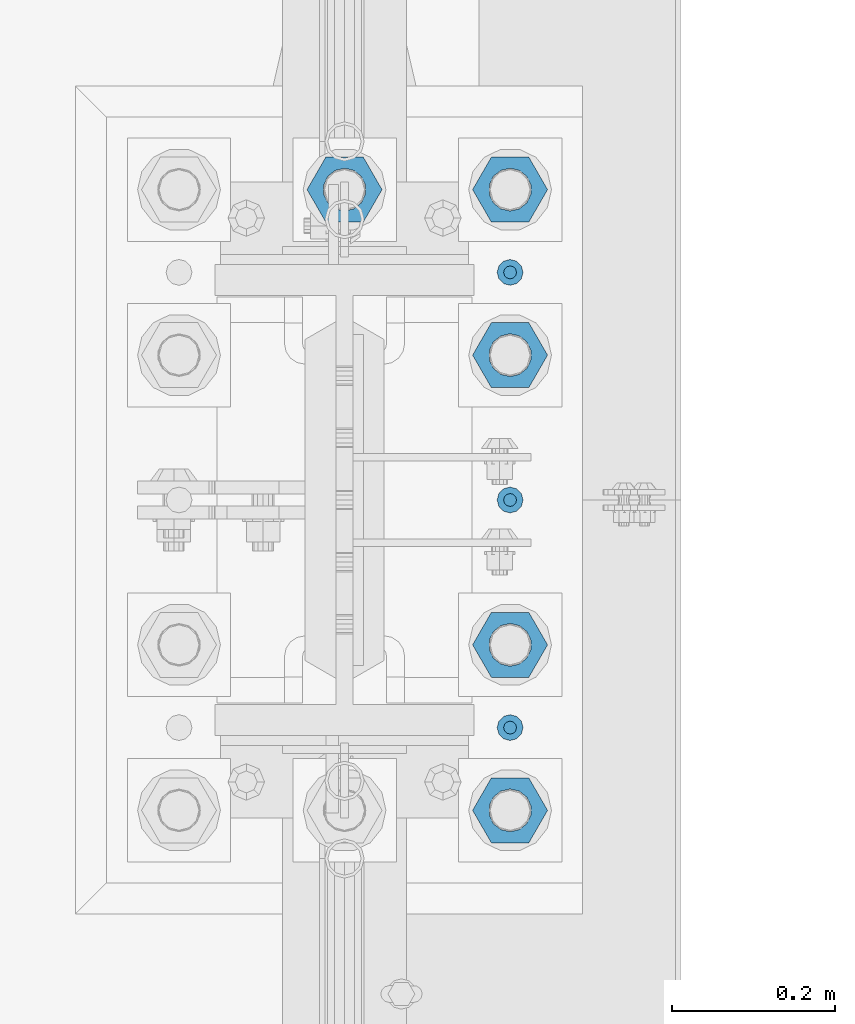
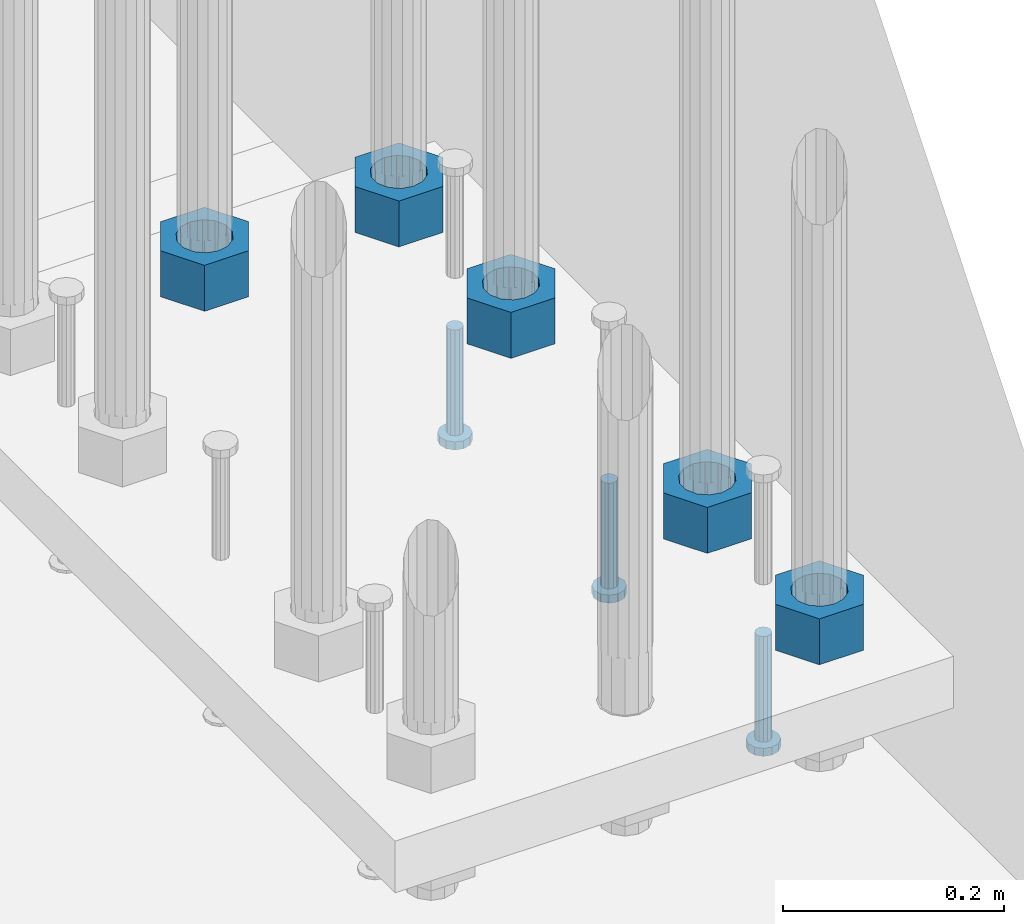
# One storey, part 1273 of 1876: 8 beams, 1 element without a shape of its own.
"""IFC2X3 building model written with IfcOpenShell, lengths in millimetres."""

from ifc_helpers import new_model, si_unit, frame, origin_with_axes, place, context, subcontext, project, spatial, faceted_brep, material, type_object, element, aggregate, save


model = new_model("IFC2X3")

# Units and contexts
model_context = context("Model", 3, precision=1e-05, world=origin_with_axes())
body_context = subcontext(model_context, "Body", "Model", "MODEL_VIEW")
ifc_project = project(units=[si_unit("LENGTHUNIT", "METRE", prefix="MILLI"), si_unit("AREAUNIT", "SQUARE_METRE"), si_unit("VOLUMEUNIT", "CUBIC_METRE"), si_unit("MASSUNIT", "GRAM", prefix="KILO"), si_unit("TIMEUNIT", "SECOND"), si_unit("PLANEANGLEUNIT", "RADIAN"), si_unit("SOLIDANGLEUNIT", "STERADIAN"), si_unit("THERMODYNAMICTEMPERATUREUNIT", "DEGREE_CELSIUS"), si_unit("LUMINOUSINTENSITYUNIT", "LUMEN")], contexts=[model_context])

# Site, building, storey
site_placement = place(None, origin_with_axes())
site = spatial("IfcSite", under=ifc_project, at=site_placement, CompositionType="ELEMENT")
building_placement = place(site_placement, origin_with_axes())
building = spatial("IfcBuilding", under=site, at=building_placement, Name="Undefined", CompositionType="ELEMENT")
storey_placement = place(building_placement, origin_with_axes())
storey = spatial("IfcBuildingStorey", under=building, at=storey_placement, Name="Undefined", CompositionType="ELEMENT", Elevation=0.0)

# Assembly, beams
assembly_placement = place(storey_placement, origin_with_axes())
assembly = element("IfcElementAssembly", 1, at=assembly_placement, inside=storey, Name="TEMPLATE", AssemblyPlace="NOTDEFINED", PredefinedType="RIGID_FRAME")
ifc_material_1 = material(Name="STEEL/A563")
beam_type_1 = type_object("IfcBeamType", Name="2_HEAVY_HEX_NUT", PredefinedType="NOTDEFINED")
beam_1_placement = place(assembly_placement, frame((7823.2, 1142.99999847412, -685.799998474121), z_axis=(0.0, 1.0, 0.0), x_axis=(0.0, 0.0, -1.0)))
beam_1 = element("IfcBeam", 2, at=beam_1_placement, type_object=beam_type_1, material=ifc_material_1, Name="NUT", ObjectType="2_HEAVY_HEX_NUT", context=body_context, shape_type="Brep", body=[
    faceted_brep([(0.0, -46.0369987487793, 9.09494701772928e-13), (0.0, -23.0184993743896, -39.869213104248), (50.8, -23.0184993743896, -39.869213104248), (50.8, -46.0369987487793, 9.09494701772928e-13), (0.0, 23.0184993743896, -39.869213104248), (50.8, 23.0184993743896, -39.869213104248), (0.0, 46.0369987487793, -9.09494701772928e-13), (50.8, 46.0369987487793, -9.09494701772928e-13), (0.0, 23.0184993743896, 39.869213104248), (50.8, 23.0184993743896, 39.869213104248), (0.0, -23.0184993743896, 39.869213104248), (50.8, -23.0184993743896, 39.869213104248), (0.0, 0.0, 26.1940002441406), (0.0, 11.3650617044514, 23.5999013092769), (50.8, 11.3650617044513, 23.5999013092771), (50.8, 0.0, 26.1940002441406), (0.0, 20.4791109456437, 16.3316083006703), (50.8, 20.4791109456439, 16.3316083006703), (0.0, 25.5370200498346, 5.82867859874477), (50.8, 25.5370200498343, 5.82867859874455), (0.0, 25.5370200498346, -5.82867859874477), (50.8, 25.5370200498343, -5.82867859874455), (0.0, 20.4791109456437, -16.3316083006703), (50.8, 20.4791109456439, -16.3316083006703), (0.0, 11.3650617044514, -23.5999013092769), (50.8, 11.3650617044514, -23.5999013092771), (0.0, 0.0, -26.1940002441406), (50.8, 0.0, -26.1940002441406), (0.0, -11.3650617044514, -23.5999013092769), (50.8, -11.3650617044513, -23.5999013092771), (0.0, -20.4791109456437, -16.3316083006703), (50.8, -20.4791109456439, -16.3316083006703), (0.0, -25.5370200498346, -5.82867859874477), (50.8, -25.5370200498343, -5.82867859874455), (0.0, -25.5370200498346, 5.82867859874477), (50.8, -25.5370200498343, 5.82867859874455), (0.0, -20.4791109456437, 16.3316083006703), (50.8, -20.4791109456439, 16.3316083006703), (0.0, -11.3650617044514, 23.5999013092769), (50.8, -11.3650617044514, 23.5999013092771)], [[[0, 1, 2, 3]], [[1, 4, 5, 2]], [[4, 6, 7, 5]], [[6, 8, 9, 7]], [[8, 10, 11, 9]], [[10, 0, 3, 11]], [[12, 13, 14, 15]], [[13, 16, 17, 14]], [[16, 18, 19, 17]], [[18, 20, 21, 19]], [[20, 22, 23, 21]], [[22, 24, 25, 23]], [[24, 26, 27, 25]], [[26, 28, 29, 27]], [[28, 30, 31, 29]], [[30, 32, 33, 31]], [[32, 34, 35, 33]], [[34, 36, 37, 35]], [[36, 38, 39, 37]], [[38, 12, 15, 39]], [[5, 7, 9, 11, 3, 2], [17, 19, 21, 23, 25, 27, 29, 31, 33, 35, 37, 39, 15, 14]], [[10, 8, 6, 4, 1, 0], [38, 36, 34, 32, 30, 28, 26, 24, 22, 20, 18, 16, 13, 12]]]),
])
beam_2_placement = place(assembly_placement, frame((7823.2, 1346.19999847412, -685.799998474121), z_axis=(0.0, 1.0, 0.0), x_axis=(0.0, 0.0, -1.0)))
beam_2 = element("IfcBeam", 3, at=beam_2_placement, type_object=beam_type_1, material=ifc_material_1, Name="NUT", ObjectType="2_HEAVY_HEX_NUT", context=body_context, shape_type="Brep", body=[
    faceted_brep([(0.0, -46.0369987487793, 9.09494701772928e-13), (0.0, -23.0184993743896, -39.869213104248), (50.8, -23.0184993743896, -39.869213104248), (50.8, -46.0369987487793, 9.09494701772928e-13), (0.0, 23.0184993743896, -39.869213104248), (50.8, 23.0184993743896, -39.869213104248), (0.0, 46.0369987487793, -9.09494701772928e-13), (50.8, 46.0369987487793, -9.09494701772928e-13), (0.0, 23.0184993743896, 39.869213104248), (50.8, 23.0184993743896, 39.869213104248), (0.0, -23.0184993743896, 39.869213104248), (50.8, -23.0184993743896, 39.869213104248), (0.0, 0.0, 26.1940002441406), (0.0, 11.3650617044514, 23.5999013092769), (50.8, 11.3650617044513, 23.5999013092771), (50.8, 0.0, 26.1940002441406), (0.0, 20.4791109456437, 16.3316083006703), (50.8, 20.4791109456439, 16.3316083006703), (0.0, 25.5370200498346, 5.82867859874477), (50.8, 25.5370200498343, 5.82867859874455), (0.0, 25.5370200498346, -5.82867859874477), (50.8, 25.5370200498343, -5.82867859874455), (0.0, 20.4791109456437, -16.3316083006703), (50.8, 20.4791109456439, -16.3316083006703), (0.0, 11.3650617044514, -23.5999013092769), (50.8, 11.3650617044514, -23.5999013092771), (0.0, 0.0, -26.1940002441406), (50.8, 0.0, -26.1940002441406), (0.0, -11.3650617044514, -23.5999013092769), (50.8, -11.3650617044513, -23.5999013092771), (0.0, -20.4791109456437, -16.3316083006703), (50.8, -20.4791109456439, -16.3316083006703), (0.0, -25.5370200498346, -5.82867859874477), (50.8, -25.5370200498343, -5.82867859874455), (0.0, -25.5370200498346, 5.82867859874477), (50.8, -25.5370200498343, 5.82867859874455), (0.0, -20.4791109456437, 16.3316083006703), (50.8, -20.4791109456439, 16.3316083006703), (0.0, -11.3650617044514, 23.5999013092769), (50.8, -11.3650617044514, 23.5999013092771)], [[[0, 1, 2, 3]], [[1, 4, 5, 2]], [[4, 6, 7, 5]], [[6, 8, 9, 7]], [[8, 10, 11, 9]], [[10, 0, 3, 11]], [[12, 13, 14, 15]], [[13, 16, 17, 14]], [[16, 18, 19, 17]], [[18, 20, 21, 19]], [[20, 22, 23, 21]], [[22, 24, 25, 23]], [[24, 26, 27, 25]], [[26, 28, 29, 27]], [[28, 30, 31, 29]], [[30, 32, 33, 31]], [[32, 34, 35, 33]], [[34, 36, 37, 35]], [[36, 38, 39, 37]], [[38, 12, 15, 39]], [[5, 7, 9, 11, 3, 2], [17, 19, 21, 23, 25, 27, 29, 31, 33, 35, 37, 39, 15, 14]], [[10, 8, 6, 4, 1, 0], [38, 36, 34, 32, 30, 28, 26, 24, 22, 20, 18, 16, 13, 12]]]),
])
beam_3_placement = place(assembly_placement, frame((7823.2, 1701.79999847412, -685.799998474121), z_axis=(0.0, 1.0, 0.0), x_axis=(0.0, 0.0, -1.0)))
beam_3 = element("IfcBeam", 4, at=beam_3_placement, type_object=beam_type_1, material=ifc_material_1, Name="NUT", ObjectType="2_HEAVY_HEX_NUT", context=body_context, shape_type="Brep", body=[
    faceted_brep([(0.0, -46.0369987487793, 9.09494701772928e-13), (0.0, -23.0184993743896, -39.869213104248), (50.8, -23.0184993743896, -39.869213104248), (50.8, -46.0369987487793, 9.09494701772928e-13), (0.0, 23.0184993743896, -39.869213104248), (50.8, 23.0184993743896, -39.869213104248), (0.0, 46.0369987487793, -9.09494701772928e-13), (50.8, 46.0369987487793, -9.09494701772928e-13), (0.0, 23.0184993743896, 39.869213104248), (50.8, 23.0184993743896, 39.869213104248), (0.0, -23.0184993743896, 39.869213104248), (50.8, -23.0184993743896, 39.869213104248), (0.0, 0.0, 26.1940002441406), (0.0, 11.3650617044514, 23.5999013092769), (50.8, 11.3650617044513, 23.5999013092771), (50.8, 0.0, 26.1940002441406), (0.0, 20.4791109456437, 16.3316083006703), (50.8, 20.4791109456439, 16.3316083006703), (0.0, 25.5370200498346, 5.82867859874477), (50.8, 25.5370200498343, 5.82867859874455), (0.0, 25.5370200498346, -5.82867859874477), (50.8, 25.5370200498343, -5.82867859874455), (0.0, 20.4791109456437, -16.3316083006703), (50.8, 20.4791109456439, -16.3316083006703), (0.0, 11.3650617044514, -23.5999013092769), (50.8, 11.3650617044514, -23.5999013092771), (0.0, 0.0, -26.1940002441406), (50.8, 0.0, -26.1940002441406), (0.0, -11.3650617044514, -23.5999013092769), (50.8, -11.3650617044513, -23.5999013092771), (0.0, -20.4791109456437, -16.3316083006703), (50.8, -20.4791109456439, -16.3316083006703), (0.0, -25.5370200498346, -5.82867859874477), (50.8, -25.5370200498343, -5.82867859874455), (0.0, -25.5370200498346, 5.82867859874477), (50.8, -25.5370200498343, 5.82867859874455), (0.0, -20.4791109456437, 16.3316083006703), (50.8, -20.4791109456439, 16.3316083006703), (0.0, -11.3650617044514, 23.5999013092769), (50.8, -11.3650617044514, 23.5999013092771)], [[[0, 1, 2, 3]], [[1, 4, 5, 2]], [[4, 6, 7, 5]], [[6, 8, 9, 7]], [[8, 10, 11, 9]], [[10, 0, 3, 11]], [[12, 13, 14, 15]], [[13, 16, 17, 14]], [[16, 18, 19, 17]], [[18, 20, 21, 19]], [[20, 22, 23, 21]], [[22, 24, 25, 23]], [[24, 26, 27, 25]], [[26, 28, 29, 27]], [[28, 30, 31, 29]], [[30, 32, 33, 31]], [[32, 34, 35, 33]], [[34, 36, 37, 35]], [[36, 38, 39, 37]], [[38, 12, 15, 39]], [[5, 7, 9, 11, 3, 2], [17, 19, 21, 23, 25, 27, 29, 31, 33, 35, 37, 39, 15, 14]], [[10, 8, 6, 4, 1, 0], [38, 36, 34, 32, 30, 28, 26, 24, 22, 20, 18, 16, 13, 12]]]),
])
beam_4_placement = place(assembly_placement, frame((7620.0, 1904.99999847412, -685.799998474121), z_axis=(0.0, -1.0, 0.0), x_axis=(0.0, 0.0, -1.0)))
beam_4 = element("IfcBeam", 5, at=beam_4_placement, type_object=beam_type_1, material=ifc_material_1, Name="NUT", ObjectType="2_HEAVY_HEX_NUT", context=body_context, shape_type="Brep", body=[
    faceted_brep([(0.0, -46.0369987487793, 9.09494701772928e-13), (0.0, -23.0184993743896, -39.869213104248), (50.8, -23.0184993743896, -39.869213104248), (50.8, -46.0369987487793, 9.09494701772928e-13), (0.0, 23.0184993743896, -39.869213104248), (50.8, 23.0184993743896, -39.869213104248), (0.0, 46.0369987487793, -9.09494701772928e-13), (50.8, 46.0369987487793, -9.09494701772928e-13), (0.0, 23.0184993743896, 39.869213104248), (50.8, 23.0184993743896, 39.869213104248), (0.0, -23.0184993743896, 39.869213104248), (50.8, -23.0184993743896, 39.869213104248), (0.0, 0.0, 26.1940002441406), (0.0, 11.3650617044514, 23.5999013092769), (50.8, 11.3650617044513, 23.5999013092771), (50.8, 0.0, 26.1940002441406), (0.0, 20.4791109456437, 16.3316083006703), (50.8, 20.4791109456439, 16.3316083006703), (0.0, 25.5370200498346, 5.82867859874477), (50.8, 25.5370200498343, 5.82867859874455), (0.0, 25.5370200498346, -5.82867859874477), (50.8, 25.5370200498343, -5.82867859874455), (0.0, 20.4791109456437, -16.3316083006703), (50.8, 20.4791109456439, -16.3316083006703), (0.0, 11.3650617044514, -23.5999013092769), (50.8, 11.3650617044514, -23.5999013092771), (0.0, 0.0, -26.1940002441406), (50.8, 0.0, -26.1940002441406), (0.0, -11.3650617044514, -23.5999013092769), (50.8, -11.3650617044513, -23.5999013092771), (0.0, -20.4791109456437, -16.3316083006703), (50.8, -20.4791109456439, -16.3316083006703), (0.0, -25.5370200498346, -5.82867859874477), (50.8, -25.5370200498343, -5.82867859874455), (0.0, -25.5370200498346, 5.82867859874477), (50.8, -25.5370200498343, 5.82867859874455), (0.0, -20.4791109456437, 16.3316083006703), (50.8, -20.4791109456439, 16.3316083006703), (0.0, -11.3650617044514, 23.5999013092769), (50.8, -11.3650617044514, 23.5999013092771)], [[[0, 1, 2, 3]], [[1, 4, 5, 2]], [[4, 6, 7, 5]], [[6, 8, 9, 7]], [[8, 10, 11, 9]], [[10, 0, 3, 11]], [[12, 13, 14, 15]], [[13, 16, 17, 14]], [[16, 18, 19, 17]], [[18, 20, 21, 19]], [[20, 22, 23, 21]], [[22, 24, 25, 23]], [[24, 26, 27, 25]], [[26, 28, 29, 27]], [[28, 30, 31, 29]], [[30, 32, 33, 31]], [[32, 34, 35, 33]], [[34, 36, 37, 35]], [[36, 38, 39, 37]], [[38, 12, 15, 39]], [[5, 7, 9, 11, 3, 2], [17, 19, 21, 23, 25, 27, 29, 31, 33, 35, 37, 39, 15, 14]], [[10, 8, 6, 4, 1, 0], [38, 36, 34, 32, 30, 28, 26, 24, 22, 20, 18, 16, 13, 12]]]),
])
beam_5_placement = place(assembly_placement, frame((7823.2, 1904.99999847412, -685.799998474121), z_axis=(0.0, 1.0, 0.0), x_axis=(0.0, 0.0, -1.0)))
beam_5 = element("IfcBeam", 6, at=beam_5_placement, type_object=beam_type_1, material=ifc_material_1, Name="NUT", ObjectType="2_HEAVY_HEX_NUT", context=body_context, shape_type="Brep", body=[
    faceted_brep([(0.0, -46.0369987487793, 9.09494701772928e-13), (0.0, -23.0184993743896, -39.869213104248), (50.8, -23.0184993743896, -39.869213104248), (50.8, -46.0369987487793, 9.09494701772928e-13), (0.0, 23.0184993743896, -39.869213104248), (50.8, 23.0184993743896, -39.869213104248), (0.0, 46.0369987487793, -9.09494701772928e-13), (50.8, 46.0369987487793, -9.09494701772928e-13), (0.0, 23.0184993743896, 39.869213104248), (50.8, 23.0184993743896, 39.869213104248), (0.0, -23.0184993743896, 39.869213104248), (50.8, -23.0184993743896, 39.869213104248), (0.0, 0.0, 26.1940002441406), (0.0, 11.3650617044514, 23.5999013092769), (50.8, 11.3650617044513, 23.5999013092771), (50.8, 0.0, 26.1940002441406), (0.0, 20.4791109456437, 16.3316083006703), (50.8, 20.4791109456439, 16.3316083006703), (0.0, 25.5370200498346, 5.82867859874477), (50.8, 25.5370200498343, 5.82867859874455), (0.0, 25.5370200498346, -5.82867859874477), (50.8, 25.5370200498343, -5.82867859874455), (0.0, 20.4791109456437, -16.3316083006703), (50.8, 20.4791109456439, -16.3316083006703), (0.0, 11.3650617044514, -23.5999013092769), (50.8, 11.3650617044514, -23.5999013092771), (0.0, 0.0, -26.1940002441406), (50.8, 0.0, -26.1940002441406), (0.0, -11.3650617044514, -23.5999013092769), (50.8, -11.3650617044513, -23.5999013092771), (0.0, -20.4791109456437, -16.3316083006703), (50.8, -20.4791109456439, -16.3316083006703), (0.0, -25.5370200498346, -5.82867859874477), (50.8, -25.5370200498343, -5.82867859874455), (0.0, -25.5370200498346, 5.82867859874477), (50.8, -25.5370200498343, 5.82867859874455), (0.0, -20.4791109456437, 16.3316083006703), (50.8, -20.4791109456439, 16.3316083006703), (0.0, -11.3650617044514, 23.5999013092769), (50.8, -11.3650617044514, 23.5999013092771)], [[[0, 1, 2, 3]], [[1, 4, 5, 2]], [[4, 6, 7, 5]], [[6, 8, 9, 7]], [[8, 10, 11, 9]], [[10, 0, 3, 11]], [[12, 13, 14, 15]], [[13, 16, 17, 14]], [[16, 18, 19, 17]], [[18, 20, 21, 19]], [[20, 22, 23, 21]], [[22, 24, 25, 23]], [[24, 26, 27, 25]], [[26, 28, 29, 27]], [[28, 30, 31, 29]], [[30, 32, 33, 31]], [[32, 34, 35, 33]], [[34, 36, 37, 35]], [[36, 38, 39, 37]], [[38, 12, 15, 39]], [[5, 7, 9, 11, 3, 2], [17, 19, 21, 23, 25, 27, 29, 31, 33, 35, 37, 39, 15, 14]], [[10, 8, 6, 4, 1, 0], [38, 36, 34, 32, 30, 28, 26, 24, 22, 20, 18, 16, 13, 12]]]),
])
ifc_material_2 = material(Name="STEEL/A108")
beam_type_2 = type_object("IfcBeamType", Name="5/8-DIA_HEADED ANCHOR STUD", PredefinedType="NOTDEFINED")
beam_6_placement = place(assembly_placement, frame((7823.2, 1803.4, -793.75), z_axis=(1.0, 0.0, 0.0), x_axis=(0.0, 0.0, -1.0)))
beam_6 = element("IfcBeam", 7, at=beam_6_placement, type_object=beam_type_2, material=ifc_material_2, Name="HEADED ANCHOR STUD", ObjectType="5/8-DIA_HEADED ANCHOR STUD", context=body_context, shape_type="Brep", body=[
    faceted_brep([(0.0, -7.94000005722046, 0.0), (0.0, -6.86999988555908, -3.97000002861023), (116.84, -6.86999988555908, -3.97000002861023), (116.84, -7.94000005722046, 0.0), (0.0, -3.97000002861023, -6.86999988555908), (116.84, -3.97000002861023, -6.86999988555908), (0.0, 0.0, -7.94000005722046), (116.84, 0.0, -7.94000005722046), (0.0, 3.97000002861023, -6.86999988555908), (116.84, 3.97000002861023, -6.86999988555908), (0.0, 6.86999988555908, -3.97000002861023), (116.84, 6.86999988555908, -3.97000002861023), (0.0, 7.94000005722046, 0.0), (116.84, 7.94000005722046, 0.0), (0.0, 6.86999988555908, 3.97000002861023), (116.84, 6.86999988555908, 3.97000002861023), (0.0, 3.97000002861023, 6.86999988555908), (116.84, 3.97000002861023, 6.86999988555908), (0.0, 0.0, 7.94000005722046), (116.84, 0.0, 7.94000005722046), (0.0, -3.97000002861023, 6.86999988555908), (116.84, -3.97000002861023, 6.86999988555908), (0.0, -6.86999988555908, 3.97000002861023), (116.84, -6.86999988555908, 3.97000002861023), (118.11, -13.75, -7.94000005722046), (118.11, -15.8800001144409, 0.0), (118.11, -7.94000005722046, -13.75), (118.11, 0.0, -15.8800001144409), (118.11, 7.94000005722046, -13.75), (118.11, 13.75, -7.94000005722046), (118.11, 15.8800001144409, 0.0), (118.11, 13.75, 7.94000005722046), (118.11, 7.94000005722046, 13.75), (118.11, 0.0, 15.8800001144409), (118.11, -7.94000005722046, 13.75), (118.11, -13.75, 7.94000005722046), (127.0, -13.75, -7.94000005722046), (127.0, -15.8800001144409, 0.0), (127.0, -7.94000005722046, -13.75), (127.0, 0.0, -15.8800001144409), (127.0, 7.94000005722046, -13.75), (127.0, 13.75, -7.94000005722046), (127.0, 15.8800001144409, 0.0), (127.0, 13.75, 7.94000005722046), (127.0, 7.94000005722046, 13.75), (127.0, 0.0, 15.8800001144409), (127.0, -7.94000005722046, 13.75), (127.0, -13.75, 7.94000005722046)], [[[0, 1, 2, 3]], [[1, 4, 5, 2]], [[4, 6, 7, 5]], [[6, 8, 9, 7]], [[8, 10, 11, 9]], [[10, 12, 13, 11]], [[12, 14, 15, 13]], [[14, 16, 17, 15]], [[16, 18, 19, 17]], [[18, 20, 21, 19]], [[20, 22, 23, 21]], [[22, 0, 3, 23]], [[22, 20, 18, 16, 14, 12, 10, 8, 6, 4, 1, 0]], [[3, 2, 24, 25]], [[2, 5, 26, 24]], [[5, 7, 27, 26]], [[7, 9, 28, 27]], [[9, 11, 29, 28]], [[11, 13, 30, 29]], [[13, 15, 31, 30]], [[15, 17, 32, 31]], [[17, 19, 33, 32]], [[19, 21, 34, 33]], [[21, 23, 35, 34]], [[23, 3, 25, 35]], [[25, 24, 36, 37]], [[24, 26, 38, 36]], [[26, 27, 39, 38]], [[27, 28, 40, 39]], [[28, 29, 41, 40]], [[29, 30, 42, 41]], [[30, 31, 43, 42]], [[31, 32, 44, 43]], [[32, 33, 45, 44]], [[33, 34, 46, 45]], [[34, 35, 47, 46]], [[35, 25, 37, 47]], [[38, 39, 40, 41, 42, 43, 44, 45, 46, 47, 37, 36]]]),
])
beam_7_placement = place(assembly_placement, frame((7823.2, 1244.6, -793.75), z_axis=(1.0, 0.0, 0.0), x_axis=(0.0, 0.0, -1.0)))
beam_7 = element("IfcBeam", 8, at=beam_7_placement, type_object=beam_type_2, material=ifc_material_2, Name="HEADED ANCHOR STUD", ObjectType="5/8-DIA_HEADED ANCHOR STUD", context=body_context, shape_type="Brep", body=[
    faceted_brep([(0.0, -7.94000005722046, 0.0), (0.0, -6.86999988555908, -3.97000002861023), (116.84, -6.86999988555908, -3.97000002861023), (116.84, -7.94000005722046, 0.0), (0.0, -3.97000002861023, -6.86999988555908), (116.84, -3.97000002861023, -6.86999988555908), (0.0, 0.0, -7.94000005722046), (116.84, 0.0, -7.94000005722046), (0.0, 3.97000002861023, -6.86999988555908), (116.84, 3.97000002861023, -6.86999988555908), (0.0, 6.86999988555908, -3.97000002861023), (116.84, 6.86999988555908, -3.97000002861023), (0.0, 7.94000005722046, 0.0), (116.84, 7.94000005722046, 0.0), (0.0, 6.86999988555908, 3.97000002861023), (116.84, 6.86999988555908, 3.97000002861023), (0.0, 3.97000002861023, 6.86999988555908), (116.84, 3.97000002861023, 6.86999988555908), (0.0, 0.0, 7.94000005722046), (116.84, 0.0, 7.94000005722046), (0.0, -3.97000002861023, 6.86999988555908), (116.84, -3.97000002861023, 6.86999988555908), (0.0, -6.86999988555908, 3.97000002861023), (116.84, -6.86999988555908, 3.97000002861023), (118.11, -13.75, -7.94000005722046), (118.11, -15.8800001144409, 0.0), (118.11, -7.94000005722046, -13.75), (118.11, 0.0, -15.8800001144409), (118.11, 7.94000005722046, -13.75), (118.11, 13.75, -7.94000005722046), (118.11, 15.8800001144409, 0.0), (118.11, 13.75, 7.94000005722046), (118.11, 7.94000005722046, 13.75), (118.11, 0.0, 15.8800001144409), (118.11, -7.94000005722046, 13.75), (118.11, -13.75, 7.94000005722046), (127.0, -13.75, -7.94000005722046), (127.0, -15.8800001144409, 0.0), (127.0, -7.94000005722046, -13.75), (127.0, 0.0, -15.8800001144409), (127.0, 7.94000005722046, -13.75), (127.0, 13.75, -7.94000005722046), (127.0, 15.8800001144409, 0.0), (127.0, 13.75, 7.94000005722046), (127.0, 7.94000005722046, 13.75), (127.0, 0.0, 15.8800001144409), (127.0, -7.94000005722046, 13.75), (127.0, -13.75, 7.94000005722046)], [[[0, 1, 2, 3]], [[1, 4, 5, 2]], [[4, 6, 7, 5]], [[6, 8, 9, 7]], [[8, 10, 11, 9]], [[10, 12, 13, 11]], [[12, 14, 15, 13]], [[14, 16, 17, 15]], [[16, 18, 19, 17]], [[18, 20, 21, 19]], [[20, 22, 23, 21]], [[22, 0, 3, 23]], [[22, 20, 18, 16, 14, 12, 10, 8, 6, 4, 1, 0]], [[3, 2, 24, 25]], [[2, 5, 26, 24]], [[5, 7, 27, 26]], [[7, 9, 28, 27]], [[9, 11, 29, 28]], [[11, 13, 30, 29]], [[13, 15, 31, 30]], [[15, 17, 32, 31]], [[17, 19, 33, 32]], [[19, 21, 34, 33]], [[21, 23, 35, 34]], [[23, 3, 25, 35]], [[25, 24, 36, 37]], [[24, 26, 38, 36]], [[26, 27, 39, 38]], [[27, 28, 40, 39]], [[28, 29, 41, 40]], [[29, 30, 42, 41]], [[30, 31, 43, 42]], [[31, 32, 44, 43]], [[32, 33, 45, 44]], [[33, 34, 46, 45]], [[34, 35, 47, 46]], [[35, 25, 37, 47]], [[38, 39, 40, 41, 42, 43, 44, 45, 46, 47, 37, 36]]]),
])
beam_8_placement = place(assembly_placement, frame((7823.2, 1524.0, -793.75), z_axis=(1.0, 0.0, 0.0), x_axis=(0.0, 0.0, -1.0)))
beam_8 = element("IfcBeam", 9, at=beam_8_placement, type_object=beam_type_2, material=ifc_material_2, Name="HEADED ANCHOR STUD", ObjectType="5/8-DIA_HEADED ANCHOR STUD", context=body_context, shape_type="Brep", body=[
    faceted_brep([(0.0, -7.94000005722046, 0.0), (0.0, -6.86999988555908, -3.97000002861023), (116.84, -6.86999988555908, -3.97000002861023), (116.84, -7.94000005722046, 0.0), (0.0, -3.97000002861023, -6.86999988555908), (116.84, -3.97000002861023, -6.86999988555908), (0.0, 0.0, -7.94000005722046), (116.84, 0.0, -7.94000005722046), (0.0, 3.97000002861023, -6.86999988555908), (116.84, 3.97000002861023, -6.86999988555908), (0.0, 6.86999988555908, -3.97000002861023), (116.84, 6.86999988555908, -3.97000002861023), (0.0, 7.94000005722046, 0.0), (116.84, 7.94000005722046, 0.0), (0.0, 6.86999988555908, 3.97000002861023), (116.84, 6.86999988555908, 3.97000002861023), (0.0, 3.97000002861023, 6.86999988555908), (116.84, 3.97000002861023, 6.86999988555908), (0.0, 0.0, 7.94000005722046), (116.84, 0.0, 7.94000005722046), (0.0, -3.97000002861023, 6.86999988555908), (116.84, -3.97000002861023, 6.86999988555908), (0.0, -6.86999988555908, 3.97000002861023), (116.84, -6.86999988555908, 3.97000002861023), (118.11, -13.75, -7.94000005722046), (118.11, -15.8800001144409, 0.0), (118.11, -7.94000005722046, -13.75), (118.11, 0.0, -15.8800001144409), (118.11, 7.94000005722046, -13.75), (118.11, 13.75, -7.94000005722046), (118.11, 15.8800001144409, 0.0), (118.11, 13.75, 7.94000005722046), (118.11, 7.94000005722046, 13.75), (118.11, 0.0, 15.8800001144409), (118.11, -7.94000005722046, 13.75), (118.11, -13.75, 7.94000005722046), (127.0, -13.75, -7.94000005722046), (127.0, -15.8800001144409, 0.0), (127.0, -7.94000005722046, -13.75), (127.0, 0.0, -15.8800001144409), (127.0, 7.94000005722046, -13.75), (127.0, 13.75, -7.94000005722046), (127.0, 15.8800001144409, 0.0), (127.0, 13.75, 7.94000005722046), (127.0, 7.94000005722046, 13.75), (127.0, 0.0, 15.8800001144409), (127.0, -7.94000005722046, 13.75), (127.0, -13.75, 7.94000005722046)], [[[0, 1, 2, 3]], [[1, 4, 5, 2]], [[4, 6, 7, 5]], [[6, 8, 9, 7]], [[8, 10, 11, 9]], [[10, 12, 13, 11]], [[12, 14, 15, 13]], [[14, 16, 17, 15]], [[16, 18, 19, 17]], [[18, 20, 21, 19]], [[20, 22, 23, 21]], [[22, 0, 3, 23]], [[22, 20, 18, 16, 14, 12, 10, 8, 6, 4, 1, 0]], [[3, 2, 24, 25]], [[2, 5, 26, 24]], [[5, 7, 27, 26]], [[7, 9, 28, 27]], [[9, 11, 29, 28]], [[11, 13, 30, 29]], [[13, 15, 31, 30]], [[15, 17, 32, 31]], [[17, 19, 33, 32]], [[19, 21, 34, 33]], [[21, 23, 35, 34]], [[23, 3, 25, 35]], [[25, 24, 36, 37]], [[24, 26, 38, 36]], [[26, 27, 39, 38]], [[27, 28, 40, 39]], [[28, 29, 41, 40]], [[29, 30, 42, 41]], [[30, 31, 43, 42]], [[31, 32, 44, 43]], [[32, 33, 45, 44]], [[33, 34, 46, 45]], [[34, 35, 47, 46]], [[35, 25, 37, 47]], [[38, 39, 40, 41, 42, 43, 44, 45, 46, 47, 37, 36]]]),
])
aggregate(assembly, [beam_1, beam_2, beam_3, beam_4, beam_5, beam_6, beam_7, beam_8])

save(model, "model.ifc")
